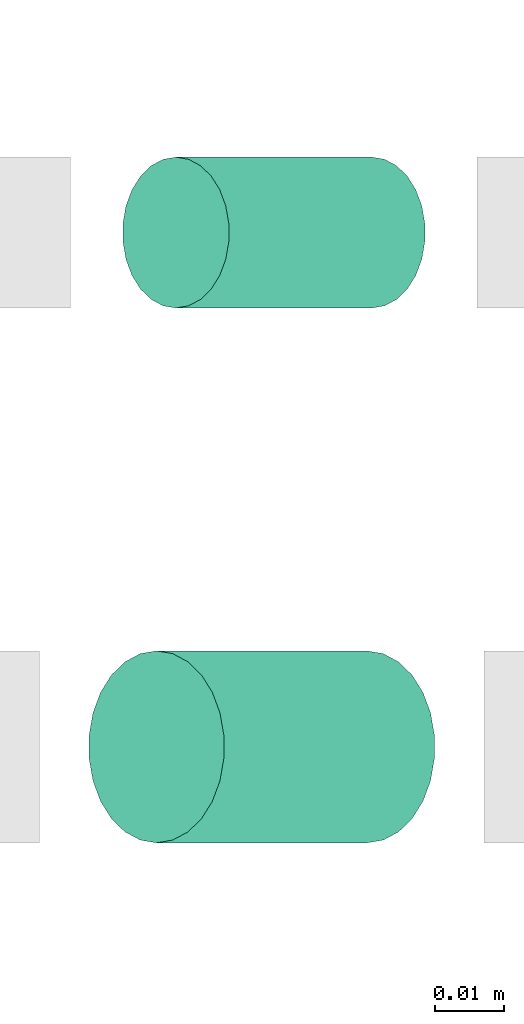
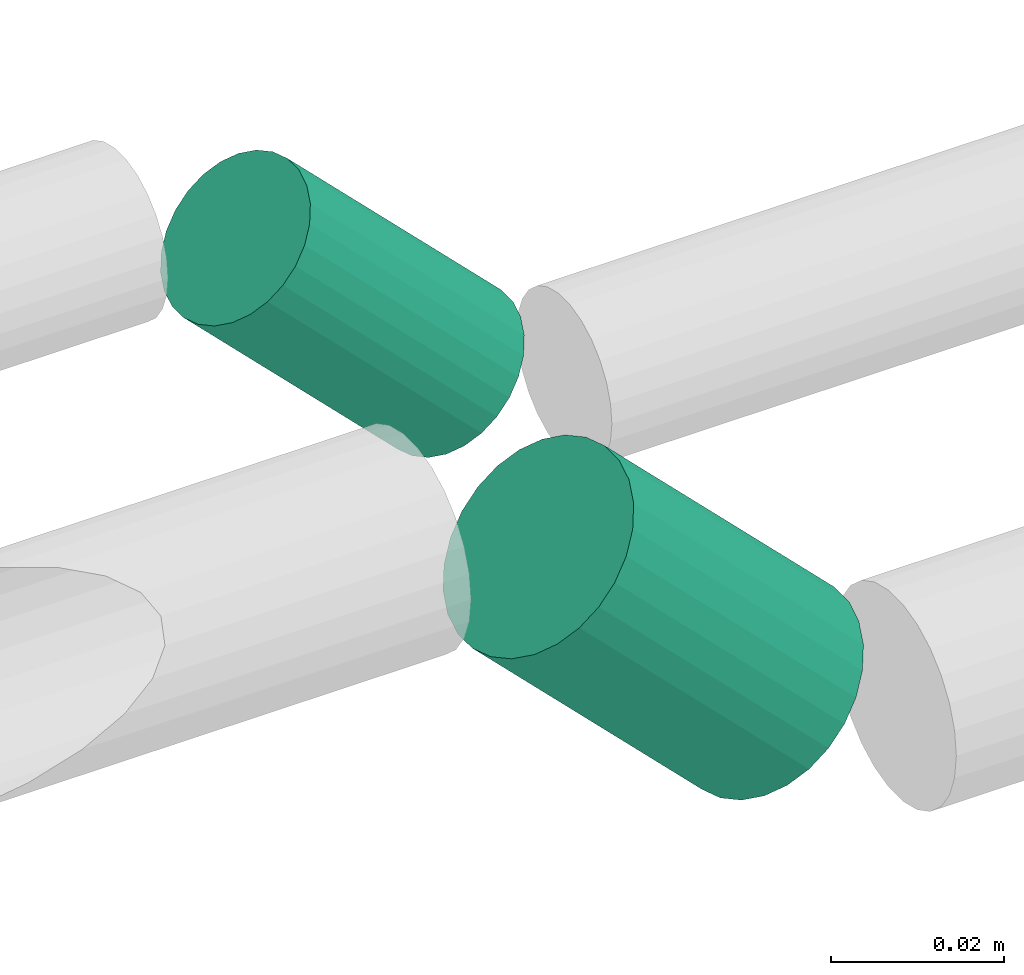
# One storey, part 255 of 331: 2 flow segments.
"""IFC2X3 building model written with IfcOpenShell, lengths in millimetres."""

import ifcopenshell
import ifcopenshell.guid

model = None  # the IFC model being written
_history = None  # IfcOwnerHistory: only IFC2X3 demands one
_inside = {}  # id of a spatial element -> (the spatial element, [elements in it])
_under = {}  # id of a project, library or spatial element -> (it, [spatial elements below it])
_declared = {}  # id of a project -> (the project, [libraries it declares])
_typed = {}  # id of a type object -> (the type object, [elements of that type])
_made_of = {}  # id of a material, layer set ... -> (it, [elements and type objects made of it])


def new_model(schema):
    """Start an empty IFC model of exactly this schema.

    Asked for "IFC4X3", IfcOpenShell would pick the latest addendum, in which some entities
    have other attributes; the version numbers below select the first issue.
    IFC2X3 requires an IfcOwnerHistory on every rooted entity: one is made here for all.
    """
    global model, _history
    if schema == "IFC4X3":
        model = ifcopenshell.file(schema_version=(4, 3, 0, 0))
    else:
        model = ifcopenshell.file(schema=schema)
    _inside.clear()
    _under.clear()
    _declared.clear()
    _typed.clear()
    _made_of.clear()
    _history = None
    if model.schema == "IFC2X3":
        org = make("IfcOrganization", Name="unknown")
        user = make(
            "IfcPersonAndOrganization",
            ThePerson=make("IfcPerson", FamilyName="unknown"),
            TheOrganization=org,
        )
        app = make(
            "IfcApplication",
            ApplicationDeveloper=org,
            Version="unknown",
            ApplicationFullName="unknown",
            ApplicationIdentifier="unknown",
        )
        _history = make(
            "IfcOwnerHistory",
            OwningUser=user,
            OwningApplication=app,
            ChangeAction="ADDED",
            CreationDate=0,
        )
    return model


def make(cls, **values):
    """One entity of the class cls with the attributes given. An attribute that is None is left unset."""
    return model.create_entity(
        cls, **{name: value for name, value in values.items() if value is not None}
    )


def entity(cls, *values):
    """Any entity or typed value of the class cls, its attributes in the order of the schema. None: left unset."""
    e = model.create_entity(cls)
    for i, value in enumerate(values):
        if value is not None:
            e[i] = value
    return e


def rooted(cls, **values):
    """An entity with a GlobalId (a new one), such as an element, a storey or a relation."""
    return make(cls, GlobalId=ifcopenshell.guid.new(), OwnerHistory=_history, **values)


def si_unit(unit_type, name, prefix=None):
    """IfcSIUnit, for example si_unit("LENGTHUNIT", "METRE", prefix="MILLI")."""
    return make("IfcSIUnit", UnitType=unit_type, Prefix=prefix, Name=name)


def converted_unit(unit_type, name, factor, base, dimensions=None, offset=None):
    """IfcConversionBasedUnit, such as the inch: factor (a typed value) times the base unit."""
    return make(
        "IfcConversionBasedUnit"
        if offset is None
        else "IfcConversionBasedUnitWithOffset",
        ConversionOffset=offset,
        Dimensions=None
        if dimensions is None
        else entity("IfcDimensionalExponents", *dimensions),
        UnitType=unit_type,
        Name=name,
        ConversionFactor=make(
            "IfcMeasureWithUnit", ValueComponent=factor, UnitComponent=base
        ),
    )


def derived_unit(unit_type, elements):
    """IfcDerivedUnit: a product of units, each with its exponent."""
    return make(
        "IfcDerivedUnit",
        Elements=[
            make("IfcDerivedUnitElement", Unit=unit, Exponent=power)
            for unit, power in elements
        ],
        UnitType=unit_type,
    )


def assignment(units):
    """IfcUnitAssignment: the units of a project."""
    return None if units is None else make("IfcUnitAssignment", Units=units)


def point(xyz):
    """IfcCartesianPoint."""
    return None if xyz is None else make("IfcCartesianPoint", Coordinates=xyz)


def direction(xyz):
    """IfcDirection."""
    return None if xyz is None else make("IfcDirection", DirectionRatios=xyz)


def frame(location, z_axis=None, x_axis=None):
    """IfcAxis2Placement3D, a coordinate frame: its origin and axes. An axis left out is left unset."""
    return make(
        "IfcAxis2Placement3D",
        Location=point(location),
        Axis=direction(z_axis),
        RefDirection=direction(x_axis),
    )


def frame_2d(location, x_axis=None):
    """IfcAxis2Placement2D, a coordinate frame in the plane: its origin and x axis."""
    return make(
        "IfcAxis2Placement2D", Location=point(location), RefDirection=direction(x_axis)
    )


def origin():
    """The frame at (0, 0, 0) with its axes left unset."""
    return frame((0.0, 0.0, 0.0))


def origin_2d_with_axis():
    """The frame at (0, 0) in the plane with the x axis (1, 0) written out."""
    return frame_2d((0.0, 0.0), x_axis=(1.0, 0.0))


def place(relative_to, where):
    """IfcLocalPlacement: puts the frame where relative to a parent placement (None: the world)."""
    return make(
        "IfcLocalPlacement", PlacementRelTo=relative_to, RelativePlacement=where
    )


def context(
    kind, dimensions, precision=None, world=None, true_north=None, identifier=None
):
    """IfcGeometricRepresentationContext, for example the 3D "Model" context."""
    return make(
        "IfcGeometricRepresentationContext",
        ContextIdentifier=identifier,
        ContextType=kind,
        CoordinateSpaceDimension=dimensions,
        Precision=precision,
        WorldCoordinateSystem=world,
        TrueNorth=true_north,
    )


def subcontext(parent, identifier, kind, view, scale=None):
    """IfcGeometricRepresentationSubContext, for example "Body" below "Model"."""
    return make(
        "IfcGeometricRepresentationSubContext",
        ContextIdentifier=identifier,
        ContextType=kind,
        ParentContext=parent,
        TargetScale=scale,
        TargetView=view,
    )


def project(units=None, contexts=None):
    """IfcProject with its units and contexts."""
    return rooted(
        "IfcProject",
        Name="project",
        RepresentationContexts=contexts,
        UnitsInContext=assignment(units),
    )


def spatial(cls, under=None, at=None, **own):
    """A site, building, storey or space (cls), placed at a placement, below another one or the project."""
    s = rooted(cls, ObjectPlacement=at, **own)
    if under is not None:
        _under.setdefault(under.id(), (under, []))[1].append(s)
    return s


def profile(cls, at=None, kind="AREA", **sizes):
    """A parametric profile (cls). Its sizes go by their IFC names, for example OverallWidth=200.0."""
    return make(cls, ProfileType=kind, Position=at, **sizes)


def circle(**sizes):
    """IfcCircleProfileDef."""
    return profile("IfcCircleProfileDef", **sizes)


def extrude(swept, where, along, depth):
    """IfcExtrudedAreaSolid: the profile swept, set in the frame where, extruded along a direction by depth."""
    return make(
        "IfcExtrudedAreaSolid",
        SweptArea=swept,
        Position=where,
        ExtrudedDirection=direction(along),
        Depth=depth,
    )


def shape(context_of_items, identifier, shape_type, items):
    """IfcShapeRepresentation: the items that make up one representation, for example the "Body"."""
    return make(
        "IfcShapeRepresentation",
        ContextOfItems=context_of_items,
        RepresentationIdentifier=identifier,
        RepresentationType=shape_type,
        Items=items,
    )


def made_of(thing, what):
    """Note that an element or type object is made of a material, layer set ...; save() writes the relation."""
    if what is not None:
        _made_of.setdefault(what.id(), (what, []))[1].append(thing)
    return thing


def type_object(cls, material=None, **own):
    """A type object (cls), such as IfcWallType, which elements share."""
    return made_of(rooted(cls, **own), material)


def element(
    cls,
    number,
    at=None,
    inside=None,
    cuts=None,
    type_object=None,
    material=None,
    context=None,
    identifier="Body",
    shape_type=None,
    held_by="IfcProductDefinitionShape",
    body=None,
    shapes=None,
    **own,
):
    """One element of the class cls, such as IfcWall. Its Tag is "e" and its number.

    at: its placement. inside: the storey or other place that contains it. cuts: it is an
    opening in that element (IfcRelVoidsElement). A single representation is given by context,
    identifier, shape_type and body (its items); several are given by shapes. held_by: the class
    of the entity that holds the representations. save() writes the other relations.
    """
    e = rooted(cls, Tag="e%d" % number, ObjectPlacement=at, **own)
    if body is not None:
        shapes = [shape(context, identifier, shape_type, body)]
    if shapes is not None:
        e.Representation = make(held_by, Representations=shapes)
    if inside is not None:
        _inside.setdefault(inside.id(), (inside, []))[1].append(e)
    if cuts is not None:
        rooted(
            "IfcRelVoidsElement", RelatingBuildingElement=cuts, RelatedOpeningElement=e
        )
    if type_object is not None:
        _typed.setdefault(type_object.id(), (type_object, []))[1].append(e)
    return made_of(e, material)


def aggregate(whole, parts):
    """IfcRelAggregates: a whole, such as a stair, and the parts it consists of."""
    return rooted("IfcRelAggregates", RelatingObject=whole, RelatedObjects=parts)


def save(model, path):
    """Write the relations noted so far, then the file.

    IfcRelAggregates (storeys below a building ...), IfcRelContainedInSpatialStructure (elements
    in a storey), IfcRelDefinesByType, IfcRelAssociatesMaterial and IfcRelDeclares: one each for
    every whole, place, type object, material and project.
    """
    for whole, parts in _under.values():
        aggregate(whole, parts)
    for where, things in _inside.values():
        rooted(
            "IfcRelContainedInSpatialStructure",
            RelatedElements=things,
            RelatingStructure=where,
        )
    for kind, things in _typed.values():
        rooted("IfcRelDefinesByType", RelatedObjects=things, RelatingType=kind)
    for what, things in _made_of.values():
        rooted("IfcRelAssociatesMaterial", RelatedObjects=things, RelatingMaterial=what)
    for by, libraries in _declared.values():
        rooted("IfcRelDeclares", RelatingContext=by, RelatedDefinitions=libraries)
    model.write(path)


model = new_model("IFC2X3")

# Units and contexts
model_context = context("Model", 3, precision=0.01, world=origin(), true_north=direction((6.12303176911189e-17, 1.0)))
body_context = subcontext(model_context, "Body", "Model", "MODEL_VIEW")
ifc_project = project(units=[si_unit("LENGTHUNIT", "METRE", prefix="MILLI"), si_unit("AREAUNIT", "SQUARE_METRE"), si_unit("VOLUMEUNIT", "CUBIC_METRE"), converted_unit("PLANEANGLEUNIT", "DEGREE", entity("IfcRatioMeasure", 0.0174532925199433), si_unit("PLANEANGLEUNIT", "RADIAN"), dimensions=[0, 0, 0, 0, 0, 0, 0]), si_unit("MASSUNIT", "GRAM", prefix="KILO"), derived_unit("MASSDENSITYUNIT", [(si_unit("MASSUNIT", "GRAM", prefix="KILO"), 1), (si_unit("LENGTHUNIT", "METRE"), -3)]), derived_unit("MOMENTOFINERTIAUNIT", [(si_unit("LENGTHUNIT", "METRE"), 4)]), si_unit("TIMEUNIT", "SECOND"), si_unit("FREQUENCYUNIT", "HERTZ"), si_unit("THERMODYNAMICTEMPERATUREUNIT", "DEGREE_CELSIUS"), derived_unit("THERMALTRANSMITTANCEUNIT", [(si_unit("MASSUNIT", "GRAM", prefix="KILO"), 1), (si_unit("THERMODYNAMICTEMPERATUREUNIT", "KELVIN"), -1), (si_unit("TIMEUNIT", "SECOND"), -3)]), derived_unit("VOLUMETRICFLOWRATEUNIT", [(si_unit("LENGTHUNIT", "METRE"), 3), (si_unit("TIMEUNIT", "SECOND"), -1)]), derived_unit("MASSFLOWRATEUNIT", [(si_unit("MASSUNIT", "GRAM", prefix="KILO"), 1), (si_unit("TIMEUNIT", "SECOND"), -1)]), derived_unit("ROTATIONALFREQUENCYUNIT", [(si_unit("TIMEUNIT", "SECOND"), -1)]), si_unit("ELECTRICCURRENTUNIT", "AMPERE"), si_unit("ELECTRICVOLTAGEUNIT", "VOLT"), si_unit("POWERUNIT", "WATT"), si_unit("FORCEUNIT", "NEWTON", prefix="KILO"), si_unit("ILLUMINANCEUNIT", "LUX"), si_unit("LUMINOUSFLUXUNIT", "LUMEN"), si_unit("LUMINOUSINTENSITYUNIT", "CANDELA"), derived_unit("USERDEFINED", [(si_unit("MASSUNIT", "GRAM", prefix="KILO"), -1), (si_unit("LENGTHUNIT", "METRE"), -2), (si_unit("TIMEUNIT", "SECOND"), 3), (si_unit("LUMINOUSFLUXUNIT", "LUMEN"), 1)]), derived_unit("LINEARVELOCITYUNIT", [(si_unit("LENGTHUNIT", "METRE"), 1), (si_unit("TIMEUNIT", "SECOND"), -1)]), si_unit("PRESSUREUNIT", "PASCAL"), derived_unit("USERDEFINED", [(si_unit("LENGTHUNIT", "METRE"), -2), (si_unit("MASSUNIT", "GRAM", prefix="KILO"), 1), (si_unit("TIMEUNIT", "SECOND"), -2)]), derived_unit("LINEARFORCEUNIT", [(si_unit("MASSUNIT", "GRAM", prefix="KILO"), 1), (si_unit("LENGTHUNIT", "METRE"), 1), (si_unit("TIMEUNIT", "SECOND"), -2), (si_unit("LENGTHUNIT", "METRE"), -1)]), derived_unit("PLANARFORCEUNIT", [(si_unit("MASSUNIT", "GRAM", prefix="KILO"), 1), (si_unit("LENGTHUNIT", "METRE"), 1), (si_unit("TIMEUNIT", "SECOND"), -2), (si_unit("LENGTHUNIT", "METRE"), -2)])], contexts=[model_context])

# Site, building, storey
site_placement = place(None, frame((0.0, -0.00077364408347762, 0.0)))
site = spatial("IfcSite", under=ifc_project, at=site_placement, CompositionType="ELEMENT")
building_placement = place(site_placement, origin())
building = spatial("IfcBuilding", under=site, at=building_placement, CompositionType="ELEMENT")
storey_placement = place(building_placement, origin())
storey = spatial("IfcBuildingStorey", under=building, at=storey_placement, CompositionType="ELEMENT", Elevation=0.0)

# Flow segments
pipe_segment_type = type_object("IfcPipeSegmentType", PredefinedType="NOTDEFINED")
flow_segment_1_placement = place(building_placement, frame((20571.5239005429, 9692.47501991276, 2946.9905142017)))
element("IfcFlowSegment", 1, at=flow_segment_1_placement, inside=storey, type_object=pipe_segment_type, context=body_context, shape_type="SweptSolid", body=[
    extrude(circle(Radius=11.0, at=origin_2d_with_axis()), frame((37.9628046040664, 12.5952722359156, 9.37344682896519), z_axis=(-0.707106781186454, 0.0, 0.707106781186641), x_axis=(0.0, 1.0, 0.0)), (0.0, 0.0, 1.0), 40.4314575050879),
])
flow_segment_2_placement = place(building_placement, frame((20566.5741530747, 9614.47501991257, 2945.57630063934)))
element("IfcFlowSegment", 2, at=flow_segment_2_placement, inside=storey, type_object=pipe_segment_type, context=body_context, shape_type="SweptSolid", body=[
    extrude(circle(Radius=14.0, at=origin_2d_with_axis()), frame((42.2054452911524, 15.595272235916, 11.4947671725196), z_axis=(-0.707106781186043, 0.0, 0.707106781187052), x_axis=(0.0, 1.0, 0.0)), (0.0, 0.0, 1.0), 43.4314575050563),
])

save(model, "model.ifc")
